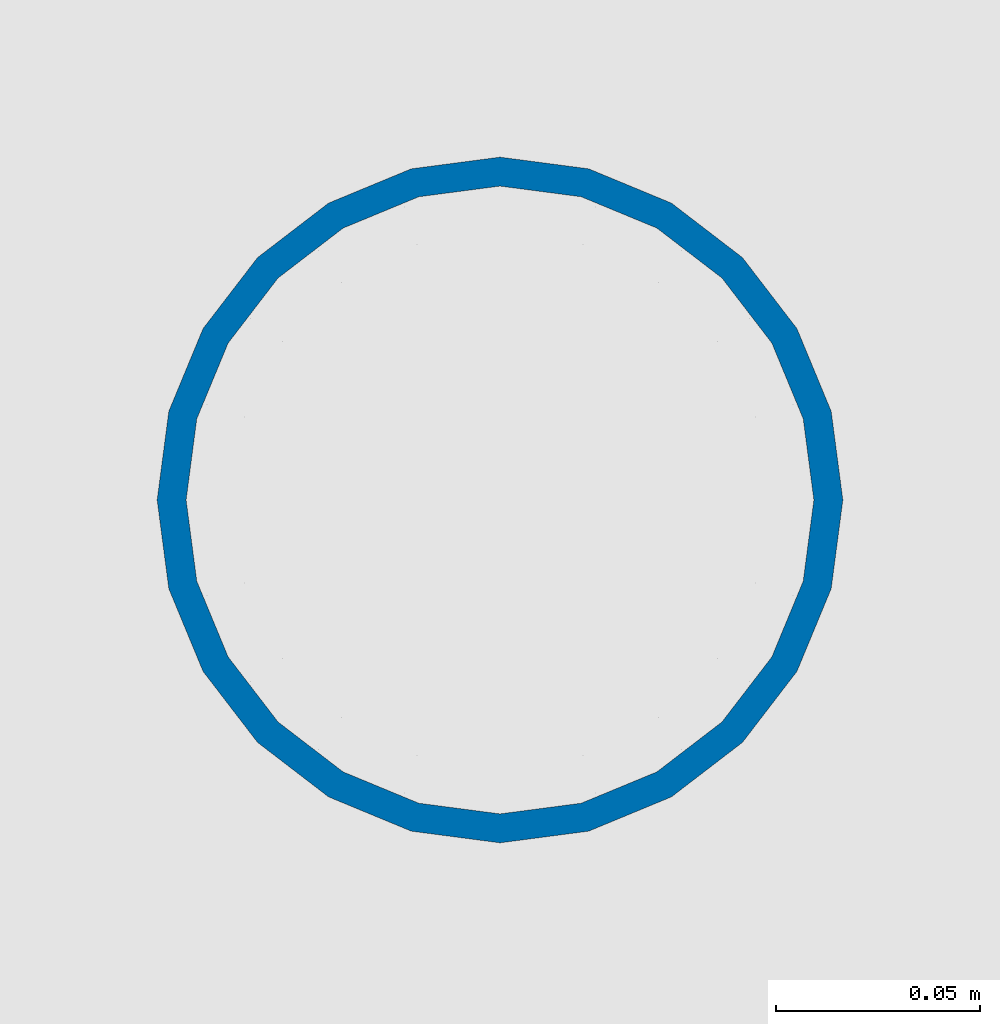
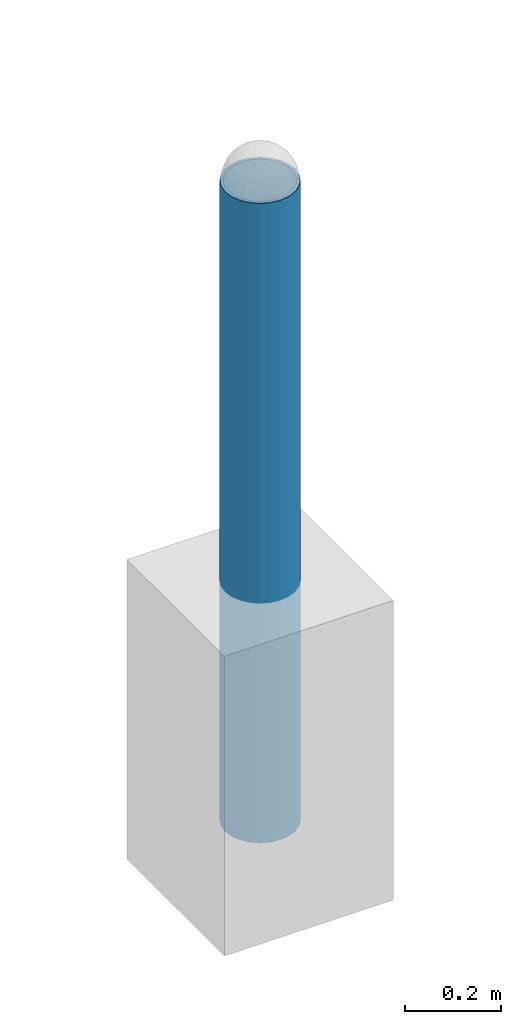
# One storey, part 1320 of 3843: 1 column, 1 element without a shape of its own.
"""IFC2X3 building model written with IfcOpenShell, lengths in millimetres."""

from ifc_helpers import new_model, si_unit, frame, origin_with_axes, place, context, subcontext, project, spatial, faceted_brep, material, type_object, element, aggregate, save


model = new_model("IFC2X3")

# Units and contexts
model_context = context("Model", 3, precision=1e-05, world=origin_with_axes())
body_context = subcontext(model_context, "Body", "Model", "MODEL_VIEW")
ifc_project = project(units=[si_unit("LENGTHUNIT", "METRE", prefix="MILLI"), si_unit("AREAUNIT", "SQUARE_METRE"), si_unit("VOLUMEUNIT", "CUBIC_METRE"), si_unit("MASSUNIT", "GRAM", prefix="KILO"), si_unit("TIMEUNIT", "SECOND"), si_unit("PLANEANGLEUNIT", "RADIAN"), si_unit("SOLIDANGLEUNIT", "STERADIAN"), si_unit("THERMODYNAMICTEMPERATUREUNIT", "DEGREE_CELSIUS"), si_unit("LUMINOUSINTENSITYUNIT", "LUMEN")], contexts=[model_context])

# Site, building, storey
site_placement = place(None, origin_with_axes())
site = spatial("IfcSite", under=ifc_project, at=site_placement, CompositionType="ELEMENT")
building_placement = place(site_placement, origin_with_axes())
building = spatial("IfcBuilding", under=site, at=building_placement, Name="Undefined", CompositionType="ELEMENT")
storey_placement = place(building_placement, origin_with_axes())
storey = spatial("IfcBuildingStorey", under=building, at=storey_placement, Name="Undefined", CompositionType="ELEMENT", Elevation=0.0)

# Assembly, column
assembly_placement = place(storey_placement, origin_with_axes())
assembly = element("IfcElementAssembly", 1, at=assembly_placement, inside=storey, Name="PIPE_BOLLARD", AssemblyPlace="NOTDEFINED", PredefinedType="RIGID_FRAME")
ifc_material = material()
column_type = type_object("IfcColumnType", Name="PIPE6SCH40", PredefinedType="NOTDEFINED")
column_placement = place(assembly_placement, frame((15156.5112912953, 47579.487152338, 29870.4), z_axis=(-1.0, 0.0, 0.0), x_axis=(0.0, 0.0, 1.0)))
column = element("IfcColumn", 2, at=column_placement, type_object=column_type, material=ifc_material, Name="PIPE_BOLLARD", ObjectType="PIPE6SCH40", context=body_context, shape_type="Brep", body=[
    faceted_brep([(0.0, -77.0890000000072, 0.0), (0.0, -74.4622560228017, 19.9521013679077), (1625.6, -74.4622560228017, 19.9521013679077), (1625.6, -77.0890000000072, 0.0), (0.0, -66.7610323523404, 38.5445), (1625.6, -66.7610323523404, 38.5445), (0.0, -54.5101546548831, 54.5101546548904), (1625.6, -54.5101546548831, 54.5101546548904), (0.0, -38.5445000000036, 66.7610323523386), (1625.6, -38.5445000000036, 66.7610323523386), (0.0, -19.9521013679041, 74.4622560227981), (1625.6, -19.9521013679041, 74.4622560227981), (0.0, 0.0, 77.0889999999999), (1625.6, 0.0, 77.0889999999999), (0.0, 19.9521013679041, 74.4622560227981), (1625.6, 19.9521013679041, 74.4622560227981), (0.0, 38.5445000000036, 66.7610323523386), (1625.6, 38.5445000000036, 66.7610323523386), (0.0, 54.5101546548831, 54.5101546548904), (1625.6, 54.5101546548831, 54.5101546548904), (0.0, 66.7610323523404, 38.5445), (1625.6, 66.7610323523404, 38.5445), (0.0, 74.4622560228017, 19.9521013679077), (1625.6, 74.4622560228017, 19.9521013679077), (0.0, 77.0890000000072, 0.0), (1625.6, 77.0890000000072, 0.0), (0.0, 74.4622560228017, -19.9521013679077), (1625.6, 74.4622560228017, -19.9521013679077), (0.0, 66.7610323523404, -38.5445), (1625.6, 66.7610323523404, -38.5445), (0.0, 54.5101546548831, -54.5101546548904), (1625.6, 54.5101546548831, -54.5101546548904), (0.0, 38.5445000000036, -66.7610323523386), (1625.6, 38.5445000000036, -66.7610323523386), (0.0, 19.9521013679041, -74.4622560227981), (1625.6, 19.9521013679041, -74.4622560227981), (0.0, 0.0, -77.0889999999999), (1625.6, 0.0, -77.0889999999999), (0.0, -19.9521013679041, -74.4622560227981), (1625.6, -19.9521013679041, -74.4622560227981), (0.0, -38.5445000000036, -66.7610323523386), (1625.6, -38.5445000000036, -66.7610323523386), (0.0, -54.5101546548831, -54.5101546548904), (1625.6, -54.5101546548831, -54.5101546548904), (0.0, -66.7610323523404, -38.5445), (1625.6, -66.7610323523404, -38.5445), (0.0, -74.4622560228017, -19.9521013679077), (1625.6, -74.4622560228017, -19.9521013679077), (0.0, -84.2010000000009, 0.0), (0.0, -81.3319204993604, -21.7928224166772), (1625.6, -81.3319204993604, -21.7928224166772), (1625.6, -84.2010000000009, 0.0), (0.0, -72.9202050240565, -42.1005000000005), (1625.6, -72.9202050240565, -42.1005000000005), (0.0, -59.5390980826924, -59.5390980826887), (1625.6, -59.5390980826924, -59.5390980826887), (0.0, -42.1005000000005, -72.9202050240528), (1625.6, -42.1005000000005, -72.9202050240528), (0.0, -21.7928224166826, -81.3319204993659), (1625.6, -21.7928224166826, -81.3319204993659), (0.0, 0.0, -84.2009999999991), (1625.6, 0.0, -84.2009999999991), (0.0, 21.7928224166826, -81.3319204993659), (1625.6, 21.7928224166826, -81.3319204993659), (0.0, 42.1005000000005, -72.9202050240528), (1625.6, 42.1005000000005, -72.9202050240528), (0.0, 59.5390980826924, -59.5390980826887), (1625.6, 59.5390980826924, -59.5390980826887), (0.0, 72.9202050240565, -42.1005000000005), (1625.6, 72.9202050240565, -42.1005000000005), (0.0, 81.3319204993604, -21.7928224166772), (1625.6, 81.3319204993604, -21.7928224166772), (0.0, 84.2010000000009, 0.0), (1625.6, 84.2010000000009, 0.0), (0.0, 81.3319204993604, 21.7928224166772), (1625.6, 81.3319204993604, 21.7928224166772), (0.0, 72.9202050240565, 42.1005000000005), (1625.6, 72.9202050240565, 42.1005000000005), (0.0, 59.5390980826924, 59.5390980826887), (1625.6, 59.5390980826924, 59.5390980826887), (0.0, 42.1005000000005, 72.9202050240528), (1625.6, 42.1005000000005, 72.9202050240528), (0.0, 21.7928224166826, 81.3319204993659), (1625.6, 21.7928224166826, 81.3319204993659), (0.0, 0.0, 84.2009999999991), (1625.6, 0.0, 84.2009999999991), (0.0, -21.7928224166826, 81.3319204993659), (1625.6, -21.7928224166826, 81.3319204993659), (0.0, -42.1005000000005, 72.9202050240528), (1625.6, -42.1005000000005, 72.9202050240528), (0.0, -59.5390980826924, 59.5390980826887), (1625.6, -59.5390980826924, 59.5390980826887), (0.0, -72.9202050240565, 42.1005000000005), (1625.6, -72.9202050240565, 42.1005000000005), (0.0, -81.3319204993604, 21.7928224166772), (1625.6, -81.3319204993604, 21.7928224166772)], [[[0, 1, 2, 3]], [[1, 4, 5, 2]], [[4, 6, 7, 5]], [[6, 8, 9, 7]], [[8, 10, 11, 9]], [[10, 12, 13, 11]], [[12, 14, 15, 13]], [[14, 16, 17, 15]], [[16, 18, 19, 17]], [[18, 20, 21, 19]], [[20, 22, 23, 21]], [[22, 24, 25, 23]], [[24, 26, 27, 25]], [[26, 28, 29, 27]], [[28, 30, 31, 29]], [[30, 32, 33, 31]], [[32, 34, 35, 33]], [[34, 36, 37, 35]], [[36, 38, 39, 37]], [[38, 40, 41, 39]], [[40, 42, 43, 41]], [[42, 44, 45, 43]], [[44, 46, 47, 45]], [[46, 0, 3, 47]], [[48, 49, 50, 51]], [[49, 52, 53, 50]], [[52, 54, 55, 53]], [[54, 56, 57, 55]], [[56, 58, 59, 57]], [[58, 60, 61, 59]], [[60, 62, 63, 61]], [[62, 64, 65, 63]], [[64, 66, 67, 65]], [[66, 68, 69, 67]], [[68, 70, 71, 69]], [[70, 72, 73, 71]], [[72, 74, 75, 73]], [[74, 76, 77, 75]], [[76, 78, 79, 77]], [[78, 80, 81, 79]], [[80, 82, 83, 81]], [[82, 84, 85, 83]], [[84, 86, 87, 85]], [[86, 88, 89, 87]], [[88, 90, 91, 89]], [[90, 92, 93, 91]], [[92, 94, 95, 93]], [[94, 48, 51, 95]], [[53, 55, 57, 59, 61, 63, 65, 67, 69, 71, 73, 75, 77, 79, 81, 83, 85, 87, 89, 91, 93, 95, 51, 50], [5, 7, 9, 11, 13, 15, 17, 19, 21, 23, 25, 27, 29, 31, 33, 35, 37, 39, 41, 43, 45, 47, 3, 2]], [[94, 92, 90, 88, 86, 84, 82, 80, 78, 76, 74, 72, 70, 68, 66, 64, 62, 60, 58, 56, 54, 52, 49, 48], [46, 44, 42, 40, 38, 36, 34, 32, 30, 28, 26, 24, 22, 20, 18, 16, 14, 12, 10, 8, 6, 4, 1, 0]]]),
])
aggregate(assembly, [column])

save(model, "model.ifc")
